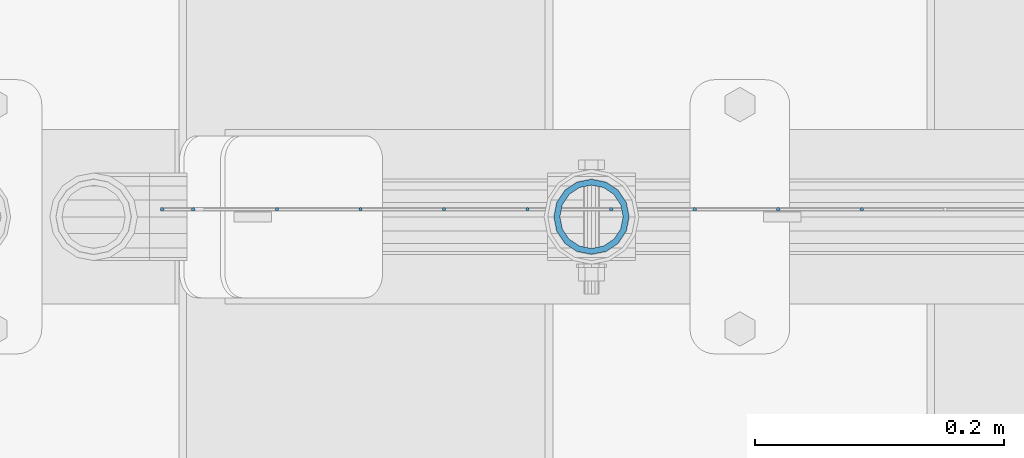
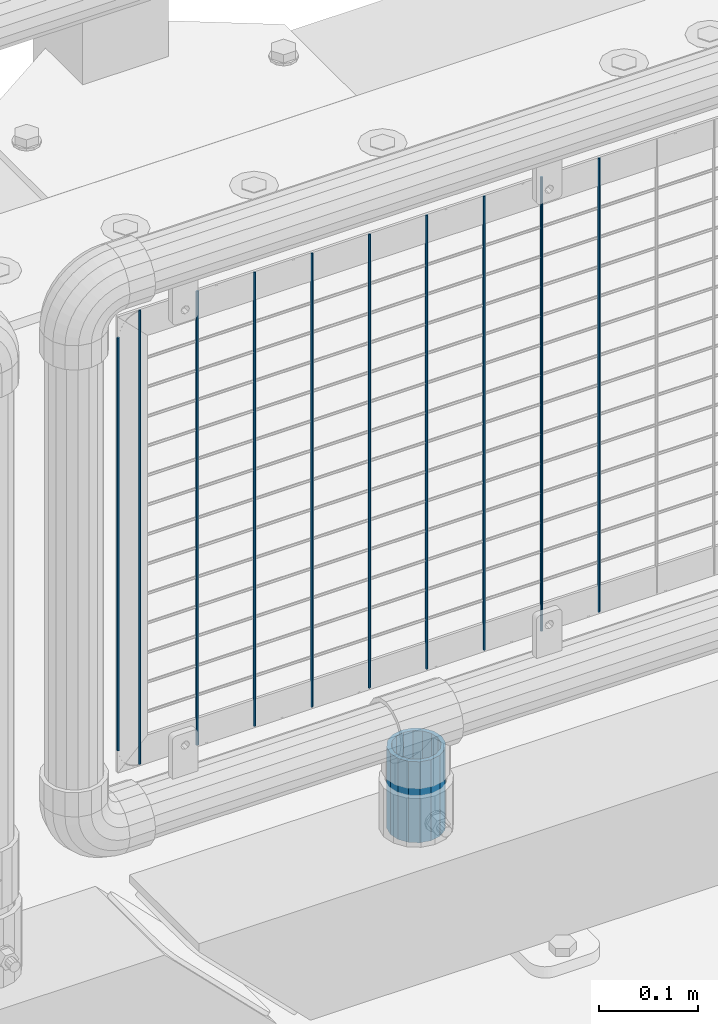
# One storey, part 81 of 193: 11 columns.
"""IFC2X3 building model written with IfcOpenShell, lengths in millimetres."""

from ifc_helpers import new_model, si_unit, frame, origin_with_axes, place, context, subcontext, project, spatial, faceted_brep, material, type_object, element, save


model = new_model("IFC2X3")

# Units and contexts
model_context = context("Model", 3, precision=1e-05, world=origin_with_axes())
body_context = subcontext(model_context, "Body", "Model", "MODEL_VIEW")
ifc_project = project(units=[si_unit("LENGTHUNIT", "METRE", prefix="MILLI"), si_unit("AREAUNIT", "SQUARE_METRE"), si_unit("VOLUMEUNIT", "CUBIC_METRE"), si_unit("MASSUNIT", "GRAM", prefix="KILO"), si_unit("TIMEUNIT", "SECOND"), si_unit("PLANEANGLEUNIT", "RADIAN"), si_unit("SOLIDANGLEUNIT", "STERADIAN"), si_unit("THERMODYNAMICTEMPERATUREUNIT", "DEGREE_CELSIUS"), si_unit("LUMINOUSINTENSITYUNIT", "LUMEN")], contexts=[model_context])

# Site, building, storey
site_placement = place(None, origin_with_axes())
site = spatial("IfcSite", under=ifc_project, at=site_placement, CompositionType="ELEMENT")
building_placement = place(site_placement, origin_with_axes())
building = spatial("IfcBuilding", under=site, at=building_placement, Name="Standard", CompositionType="ELEMENT")
storey_placement = place(building_placement, origin_with_axes())
storey = spatial("IfcBuildingStorey", under=building, at=storey_placement, Name="Undefined", CompositionType="ELEMENT", Elevation=0.0)

# Columns
ifc_material_1 = material()
column_type_1 = type_object("IfcColumnType", PredefinedType="NOTDEFINED")
column_1_placement = place(storey_placement, frame((-29719.0, 28664.5, 168.019999999998), z_axis=(-1.0, 0.0, 0.0), x_axis=(0.0, 0.0, 1.0)))
element("IfcColumn", 1, at=column_1_placement, inside=storey, type_object=column_type_1, material=ifc_material_1, context=body_context, shape_type="Brep", body=[
    faceted_brep([(0.0, -25.3499999999985, 0.0), (0.0, -23.4203461491597, 9.70102501045403), (100.0, -23.4203461491597, 9.70102501045403), (100.0, -25.3499999999985, 0.0), (0.0, -17.9251569030785, 17.9251569030785), (100.0, -17.9251569030785, 17.9251569030785), (0.0, -9.70102501045403, 23.4203461491597), (100.0, -9.70102501045403, 23.4203461491597), (0.0, 0.0, 25.3499999999985), (100.0, 0.0, 25.3499999999985), (0.0, 9.70102501045403, 23.4203461491597), (100.0, 9.70102501045403, 23.4203461491597), (0.0, 17.9251569030785, 17.9251569030785), (100.0, 17.9251569030785, 17.9251569030785), (0.0, 23.4203461491597, 9.70102501045403), (100.0, 23.4203461491597, 9.70102501045403), (0.0, 25.3499999999985, 0.0), (100.0, 25.3499999999985, 0.0), (0.0, 23.4203461491597, -9.70102501045403), (100.0, 23.4203461491597, -9.70102501045403), (0.0, 17.9251569030785, -17.9251569030785), (100.0, 17.9251569030785, -17.9251569030785), (0.0, 9.70102501045403, -23.4203461491597), (100.0, 9.70102501045403, -23.4203461491597), (0.0, 0.0, -25.3499999999985), (100.0, 0.0, -25.3499999999985), (0.0, -9.70102501045403, -23.4203461491597), (100.0, -9.70102501045403, -23.4203461491597), (0.0, -17.9251569030785, -17.9251569030785), (100.0, -17.9251569030785, -17.9251569030785), (0.0, -23.4203461491597, -9.70102501045403), (100.0, -23.4203461491597, -9.70102501045403), (0.0, -30.1500000000015, 0.0), (0.0, -27.8549679052157, -11.5379054858058), (100.0, -27.8549679052157, -11.5379054858058), (100.0, -30.1500000000015, 0.0), (0.0, -21.3192694527752, -21.3192694527752), (100.0, -21.3192694527752, -21.3192694527752), (0.0, -11.5379054858058, -27.8549679052157), (100.0, -11.5379054858058, -27.8549679052157), (0.0, 0.0, -30.1500000000015), (100.0, 0.0, -30.1500000000015), (0.0, 11.5379054858058, -27.8549679052157), (100.0, 11.5379054858058, -27.8549679052157), (0.0, 21.3192694527752, -21.3192694527752), (100.0, 21.3192694527752, -21.3192694527752), (0.0, 27.8549679052157, -11.5379054858058), (100.0, 27.8549679052157, -11.5379054858058), (0.0, 30.1500000000015, 0.0), (100.0, 30.1500000000015, 0.0), (0.0, 27.8549679052157, 11.5379054858058), (100.0, 27.8549679052157, 11.5379054858058), (0.0, 21.3192694527752, 21.3192694527752), (100.0, 21.3192694527752, 21.3192694527752), (0.0, 11.5379054858058, 27.8549679052157), (100.0, 11.5379054858058, 27.8549679052157), (0.0, 0.0, 30.1500000000015), (100.0, 0.0, 30.1500000000015), (0.0, -11.5379054858058, 27.8549679052157), (100.0, -11.5379054858058, 27.8549679052157), (0.0, -21.3192694527752, 21.3192694527752), (100.0, -21.3192694527752, 21.3192694527752), (0.0, -27.8549679052157, 11.5379054858058), (100.0, -27.8549679052157, 11.5379054858058)], [[[0, 1, 2, 3]], [[1, 4, 5, 2]], [[4, 6, 7, 5]], [[6, 8, 9, 7]], [[8, 10, 11, 9]], [[10, 12, 13, 11]], [[12, 14, 15, 13]], [[14, 16, 17, 15]], [[16, 18, 19, 17]], [[18, 20, 21, 19]], [[20, 22, 23, 21]], [[22, 24, 25, 23]], [[24, 26, 27, 25]], [[26, 28, 29, 27]], [[28, 30, 31, 29]], [[30, 0, 3, 31]], [[32, 33, 34, 35]], [[33, 36, 37, 34]], [[36, 38, 39, 37]], [[38, 40, 41, 39]], [[40, 42, 43, 41]], [[42, 44, 45, 43]], [[44, 46, 47, 45]], [[46, 48, 49, 47]], [[48, 50, 51, 49]], [[50, 52, 53, 51]], [[52, 54, 55, 53]], [[54, 56, 57, 55]], [[56, 58, 59, 57]], [[58, 60, 61, 59]], [[60, 62, 63, 61]], [[62, 32, 35, 63]], [[37, 39, 41, 43, 45, 47, 49, 51, 53, 55, 57, 59, 61, 63, 35, 34], [5, 7, 9, 11, 13, 15, 17, 19, 21, 23, 25, 27, 29, 31, 3, 2]], [[62, 60, 58, 56, 54, 52, 50, 48, 46, 44, 42, 40, 38, 36, 33, 32], [30, 28, 26, 24, 22, 20, 18, 16, 14, 12, 10, 8, 6, 4, 1, 0]]]),
])
ifc_material_2 = material(Name="Misc_Undefined")
column_type_2 = type_object("IfcColumnType", Name="D3", PredefinedType="NOTDEFINED")
for number, where, z_axis, x_axis in (
    (2, (-29502.1659999999, 28670.4998693538, 353.02), (-1.0, 0.0, 0.0), (0.0, 0.0, 1.0)),
    (3, (-29703.2499999999, 28670.4999119802, 353.02), (-1.0, 0.0, 0.0), (0.0, 0.0, 1.0)),
    (4, (-29770.2779999999, 28670.499926189, 353.02), (-1.0, 0.0, 0.0), (0.0, 0.0, 1.0)),
    (5, (-29837.3059999999, 28670.4999403979, 353.02), (-1.0, 0.0, 0.0), (0.0, 0.0, 1.0)),
    (6, (-29636.2219999999, 28670.4998977714, 353.02), (-1.0, 0.0, 0.0), (0.0, 0.0, 1.0)),
    (7, (-29904.334, 28670.4999546067, 353.02), (-1.0, 0.0, 0.0), (0.0, 0.0, 1.0)),
    (8, (-29569.1939999999, 28670.4998835626, 353.02), (-1.0, 0.0, 0.0), (0.0, 0.0, 1.0)),
    (9, (-29971.362, 28670.4999688155, 353.02), (-1.0, 0.0, 0.0), (0.0, 0.0, 1.0)),
):
    element("IfcColumn", number, at=place(storey_placement, frame(where, z_axis=z_axis, x_axis=x_axis)), inside=storey, type_object=column_type_2, material=ifc_material_2, ObjectType="D3", context=body_context, shape_type="Brep", body=[
        faceted_brep([(0.0, -1.49999999999636, 3.63797880709171e-12), (0.0, -0.75, -1.29903810567669), (560.0, -0.75, -1.29903810567703), (560.0, -1.5, 0.0), (0.0, 0.75, -1.29903810567669), (560.0, 0.75, -1.29903810567703), (0.0, 1.50000000000364, 7.27595761418343e-12), (560.0, 1.5, 0.0), (0.0, 0.75, 1.29903810567669), (560.0, 0.75, 1.29903810567703), (0.0, -0.75, 1.29903810567669), (560.0, -0.75, 1.29903810567703)], [[[0, 1, 2, 3]], [[1, 4, 5, 2]], [[4, 6, 7, 5]], [[6, 8, 9, 7]], [[8, 10, 11, 9]], [[10, 0, 3, 11]], [[5, 7, 9, 11, 3, 2]], [[10, 8, 6, 4, 1, 0]]]),
    ])
column_2_placement = place(storey_placement, frame((-30063.39, 28670.4999883292, 378.02), z_axis=(-1.0, 0.0, 0.0), x_axis=(0.0, 0.0, 1.0)))
element("IfcColumn", 10, at=column_2_placement, inside=storey, type_object=column_type_2, material=ifc_material_2, ObjectType="D3", context=body_context, shape_type="Brep", body=[
    faceted_brep([(0.0, -1.49999999999636, 3.63797880709171e-12), (0.0, -0.75, -1.29903810567669), (510.0, -0.75, -1.29903810567703), (510.0, -1.5, 0.0), (0.0, 0.75, -1.29903810567669), (510.0, 0.75, -1.29903810567703), (0.0, 1.50000000000364, 7.27595761418343e-12), (510.0, 1.5, 0.0), (0.0, 0.75, 1.29903810567669), (510.0, 0.75, 1.29903810567703), (0.0, -0.75, 1.29903810567669), (510.0, -0.75, 1.29903810567703)], [[[0, 1, 2, 3]], [[1, 4, 5, 2]], [[4, 6, 7, 5]], [[6, 8, 9, 7]], [[8, 10, 11, 9]], [[10, 0, 3, 11]], [[5, 7, 9, 11, 3, 2]], [[10, 8, 6, 4, 1, 0]]]),
])
column_3_placement = place(storey_placement, frame((-30038.39, 28670.4999830243, 353.02), z_axis=(-1.0, 0.0, 0.0), x_axis=(0.0, 0.0, 1.0)))
element("IfcColumn", 11, at=column_3_placement, inside=storey, type_object=column_type_2, material=ifc_material_2, ObjectType="D3", context=body_context, shape_type="Brep", body=[
    faceted_brep([(0.0, -1.49999999999636, 3.63797880709171e-12), (0.0, -0.75, -1.29903810567669), (560.0, -0.75, -1.29903810567703), (560.0, -1.5, 0.0), (0.0, 0.75, -1.29903810567669), (560.0, 0.75, -1.29903810567703), (0.0, 1.50000000000364, 7.27595761418343e-12), (560.0, 1.5, 0.0), (0.0, 0.75, 1.29903810567669), (560.0, 0.75, 1.29903810567703), (0.0, -0.75, 1.29903810567669), (560.0, -0.75, 1.29903810567703)], [[[0, 1, 2, 3]], [[1, 4, 5, 2]], [[4, 6, 7, 5]], [[6, 8, 9, 7]], [[8, 10, 11, 9]], [[10, 0, 3, 11]], [[5, 7, 9, 11, 3, 2]], [[10, 8, 6, 4, 1, 0]]]),
])

save(model, "model.ifc")
